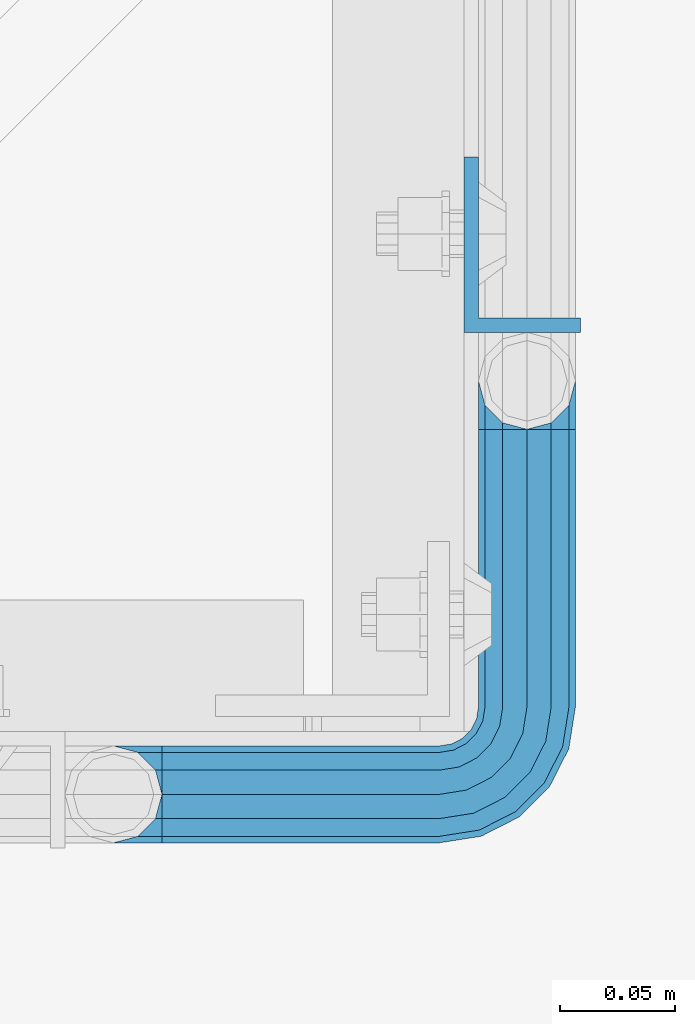
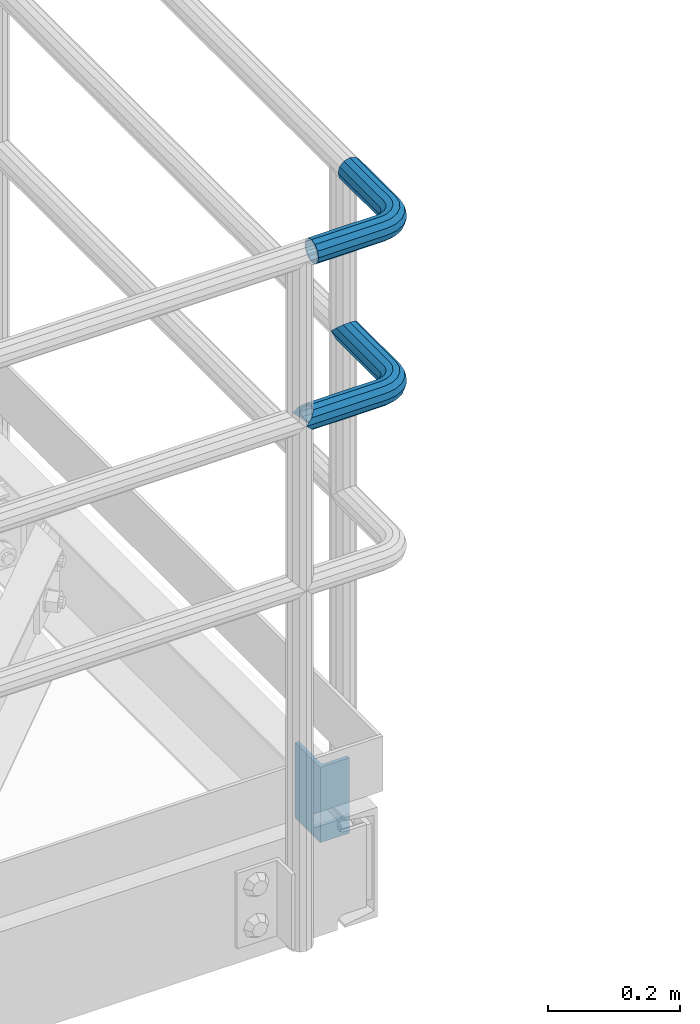
# One storey, part 1102 of 1876: 3 beams, 2 elements without a shape of their own.
"""IFC2X3 building model written with IfcOpenShell, lengths in millimetres."""

import ifcopenshell
import ifcopenshell.guid

model = None  # the IFC model being written
_history = None  # IfcOwnerHistory: only IFC2X3 demands one
_inside = {}  # id of a spatial element -> (the spatial element, [elements in it])
_under = {}  # id of a project, library or spatial element -> (it, [spatial elements below it])
_declared = {}  # id of a project -> (the project, [libraries it declares])
_typed = {}  # id of a type object -> (the type object, [elements of that type])
_made_of = {}  # id of a material, layer set ... -> (it, [elements and type objects made of it])


def new_model(schema):
    """Start an empty IFC model of exactly this schema.

    Asked for "IFC4X3", IfcOpenShell would pick the latest addendum, in which some entities
    have other attributes; the version numbers below select the first issue.
    IFC2X3 requires an IfcOwnerHistory on every rooted entity: one is made here for all.
    """
    global model, _history
    if schema == "IFC4X3":
        model = ifcopenshell.file(schema_version=(4, 3, 0, 0))
    else:
        model = ifcopenshell.file(schema=schema)
    _inside.clear()
    _under.clear()
    _declared.clear()
    _typed.clear()
    _made_of.clear()
    _history = None
    if model.schema == "IFC2X3":
        org = make("IfcOrganization", Name="unknown")
        user = make(
            "IfcPersonAndOrganization",
            ThePerson=make("IfcPerson", FamilyName="unknown"),
            TheOrganization=org,
        )
        app = make(
            "IfcApplication",
            ApplicationDeveloper=org,
            Version="unknown",
            ApplicationFullName="unknown",
            ApplicationIdentifier="unknown",
        )
        _history = make(
            "IfcOwnerHistory",
            OwningUser=user,
            OwningApplication=app,
            ChangeAction="ADDED",
            CreationDate=0,
        )
    return model


def make(cls, **values):
    """One entity of the class cls with the attributes given. An attribute that is None is left unset."""
    return model.create_entity(
        cls, **{name: value for name, value in values.items() if value is not None}
    )


def rooted(cls, **values):
    """An entity with a GlobalId (a new one), such as an element, a storey or a relation."""
    return make(cls, GlobalId=ifcopenshell.guid.new(), OwnerHistory=_history, **values)


def si_unit(unit_type, name, prefix=None):
    """IfcSIUnit, for example si_unit("LENGTHUNIT", "METRE", prefix="MILLI")."""
    return make("IfcSIUnit", UnitType=unit_type, Prefix=prefix, Name=name)


def assignment(units):
    """IfcUnitAssignment: the units of a project."""
    return None if units is None else make("IfcUnitAssignment", Units=units)


def point(xyz):
    """IfcCartesianPoint."""
    return None if xyz is None else make("IfcCartesianPoint", Coordinates=xyz)


def direction(xyz):
    """IfcDirection."""
    return None if xyz is None else make("IfcDirection", DirectionRatios=xyz)


def frame(location, z_axis=None, x_axis=None):
    """IfcAxis2Placement3D, a coordinate frame: its origin and axes. An axis left out is left unset."""
    return make(
        "IfcAxis2Placement3D",
        Location=point(location),
        Axis=direction(z_axis),
        RefDirection=direction(x_axis),
    )


def origin_with_axes():
    """The frame at (0, 0, 0) with the z axis (0, 0, 1) and the x axis (1, 0, 0) written out."""
    return frame((0.0, 0.0, 0.0), z_axis=(0.0, 0.0, 1.0), x_axis=(1.0, 0.0, 0.0))


def place(relative_to, where):
    """IfcLocalPlacement: puts the frame where relative to a parent placement (None: the world)."""
    return make(
        "IfcLocalPlacement", PlacementRelTo=relative_to, RelativePlacement=where
    )


def context(
    kind, dimensions, precision=None, world=None, true_north=None, identifier=None
):
    """IfcGeometricRepresentationContext, for example the 3D "Model" context."""
    return make(
        "IfcGeometricRepresentationContext",
        ContextIdentifier=identifier,
        ContextType=kind,
        CoordinateSpaceDimension=dimensions,
        Precision=precision,
        WorldCoordinateSystem=world,
        TrueNorth=true_north,
    )


def subcontext(parent, identifier, kind, view, scale=None):
    """IfcGeometricRepresentationSubContext, for example "Body" below "Model"."""
    return make(
        "IfcGeometricRepresentationSubContext",
        ContextIdentifier=identifier,
        ContextType=kind,
        ParentContext=parent,
        TargetScale=scale,
        TargetView=view,
    )


def project(units=None, contexts=None):
    """IfcProject with its units and contexts."""
    return rooted(
        "IfcProject",
        Name="project",
        RepresentationContexts=contexts,
        UnitsInContext=assignment(units),
    )


def spatial(cls, under=None, at=None, **own):
    """A site, building, storey or space (cls), placed at a placement, below another one or the project."""
    s = rooted(cls, ObjectPlacement=at, **own)
    if under is not None:
        _under.setdefault(under.id(), (under, []))[1].append(s)
    return s


def faces_of(points, faces, orient=None, outer=None):
    """IfcFace entities. A face is a list of loops; a loop is a list of indices into points, from 0.

    orient and outer hold one flag for each loop. By default every Orientation is true, the
    first loop of a face is its IfcFaceOuterBound and the others are IfcFaceBound.
    """
    made = []
    for i, loops in enumerate(faces):
        bounds = []
        for j, loop in enumerate(loops):
            is_outer = j == 0 if outer is None else outer[i][j]
            bounds.append(
                make(
                    "IfcFaceOuterBound" if is_outer else "IfcFaceBound",
                    Bound=make("IfcPolyLoop", Polygon=[points[k] for k in loop]),
                    Orientation=True if orient is None else orient[i][j],
                )
            )
        made.append(make("IfcFace", Bounds=bounds))
    return made


def faceted_brep(points, faces, orient=None, outer=None, voids=None):
    """IfcFacetedBrep: a solid bounded by flat faces; with voids (closed shells), ...WithVoids."""
    shared = [point(p) for p in points]
    hull = make("IfcClosedShell", CfsFaces=faces_of(shared, faces, orient, outer))
    if voids is None:
        return make("IfcFacetedBrep", Outer=hull)
    return make(
        "IfcFacetedBrepWithVoids",
        Outer=hull,
        Voids=[
            make(cls, CfsFaces=faces_of(shared, fs, o, b)) for cls, fs, o, b in voids
        ],
    )


def shape(context_of_items, identifier, shape_type, items):
    """IfcShapeRepresentation: the items that make up one representation, for example the "Body"."""
    return make(
        "IfcShapeRepresentation",
        ContextOfItems=context_of_items,
        RepresentationIdentifier=identifier,
        RepresentationType=shape_type,
        Items=items,
    )


def material(Name=None, Category=None):
    """IfcMaterial."""
    return make("IfcMaterial", Name=Name, Category=Category)


def made_of(thing, what):
    """Note that an element or type object is made of a material, layer set ...; save() writes the relation."""
    if what is not None:
        _made_of.setdefault(what.id(), (what, []))[1].append(thing)
    return thing


def type_object(cls, material=None, **own):
    """A type object (cls), such as IfcWallType, which elements share."""
    return made_of(rooted(cls, **own), material)


def element(
    cls,
    number,
    at=None,
    inside=None,
    cuts=None,
    type_object=None,
    material=None,
    context=None,
    identifier="Body",
    shape_type=None,
    held_by="IfcProductDefinitionShape",
    body=None,
    shapes=None,
    **own,
):
    """One element of the class cls, such as IfcWall. Its Tag is "e" and its number.

    at: its placement. inside: the storey or other place that contains it. cuts: it is an
    opening in that element (IfcRelVoidsElement). A single representation is given by context,
    identifier, shape_type and body (its items); several are given by shapes. held_by: the class
    of the entity that holds the representations. save() writes the other relations.
    """
    e = rooted(cls, Tag="e%d" % number, ObjectPlacement=at, **own)
    if body is not None:
        shapes = [shape(context, identifier, shape_type, body)]
    if shapes is not None:
        e.Representation = make(held_by, Representations=shapes)
    if inside is not None:
        _inside.setdefault(inside.id(), (inside, []))[1].append(e)
    if cuts is not None:
        rooted(
            "IfcRelVoidsElement", RelatingBuildingElement=cuts, RelatedOpeningElement=e
        )
    if type_object is not None:
        _typed.setdefault(type_object.id(), (type_object, []))[1].append(e)
    return made_of(e, material)


def aggregate(whole, parts):
    """IfcRelAggregates: a whole, such as a stair, and the parts it consists of."""
    return rooted("IfcRelAggregates", RelatingObject=whole, RelatedObjects=parts)


def save(model, path):
    """Write the relations noted so far, then the file.

    IfcRelAggregates (storeys below a building ...), IfcRelContainedInSpatialStructure (elements
    in a storey), IfcRelDefinesByType, IfcRelAssociatesMaterial and IfcRelDeclares: one each for
    every whole, place, type object, material and project.
    """
    for whole, parts in _under.values():
        aggregate(whole, parts)
    for where, things in _inside.values():
        rooted(
            "IfcRelContainedInSpatialStructure",
            RelatedElements=things,
            RelatingStructure=where,
        )
    for kind, things in _typed.values():
        rooted("IfcRelDefinesByType", RelatedObjects=things, RelatingType=kind)
    for what, things in _made_of.values():
        rooted("IfcRelAssociatesMaterial", RelatedObjects=things, RelatingMaterial=what)
    for by, libraries in _declared.values():
        rooted("IfcRelDeclares", RelatingContext=by, RelatedDefinitions=libraries)
    model.write(path)


model = new_model("IFC2X3")

# Units and contexts
model_context = context("Model", 3, precision=1e-05, world=origin_with_axes())
body_context = subcontext(model_context, "Body", "Model", "MODEL_VIEW")
ifc_project = project(units=[si_unit("LENGTHUNIT", "METRE", prefix="MILLI"), si_unit("AREAUNIT", "SQUARE_METRE"), si_unit("VOLUMEUNIT", "CUBIC_METRE"), si_unit("MASSUNIT", "GRAM", prefix="KILO"), si_unit("TIMEUNIT", "SECOND"), si_unit("PLANEANGLEUNIT", "RADIAN"), si_unit("SOLIDANGLEUNIT", "STERADIAN"), si_unit("THERMODYNAMICTEMPERATUREUNIT", "DEGREE_CELSIUS"), si_unit("LUMINOUSINTENSITYUNIT", "LUMEN")], contexts=[model_context])

# Site, building, storey
site_placement = place(None, origin_with_axes())
site = spatial("IfcSite", under=ifc_project, at=site_placement, CompositionType="ELEMENT")
building_placement = place(site_placement, origin_with_axes())
building = spatial("IfcBuilding", under=site, at=building_placement, Name="Undefined", CompositionType="ELEMENT")
storey_placement = place(building_placement, origin_with_axes())
storey = spatial("IfcBuildingStorey", under=building, at=storey_placement, Name="Undefined", CompositionType="ELEMENT", Elevation=0.0)

# Assembly, beams
assembly_1_placement = place(storey_placement, origin_with_axes())
assembly_1 = element("IfcElementAssembly", 1, at=assembly_1_placement, inside=storey, Name="HANDRAIL", AssemblyPlace="NOTDEFINED", PredefinedType="RIGID_FRAME")
ifc_material_1 = material()
beam_type_1 = type_object("IfcBeamType", Name="PIPE1-1/4STD", PredefinedType="NOTDEFINED")
beam_1_placement = place(assembly_1_placement, frame((6845.30143150122, -15432.4964042969, 8785.225), z_axis=(0.0, 0.0, -1.0), x_axis=(1.0, 0.0, 0.0)))
beam_1 = element("IfcBeam", 2, at=beam_1_placement, type_object=beam_type_1, material=ifc_material_1, Name="HANDRAIL", ObjectType="PIPE1-1/4STD", context=body_context, shape_type="Brep", body=[
    faceted_brep([(158.747132080079, -179.832000732422, 1.81898940354586e-12), (161.571584517495, -169.290999999999, -10.5409999999974), (161.571584517495, -169.290999999999, 10.5410000000029), (188.592132080079, -161.098037455637, -15.1779612267237), (179.829132080079, -158.749999999998, -17.525999999998), (179.829132080079, -158.749999999998, -21.0819999999985), (190.370132080079, -161.574452437415, -18.2575475625817), (190.370136997563, -161.574452437415, -13.3999563092402), (171.066132080079, -161.098040090908, -15.1779612267237), (169.288136997563, -161.574452437415, -13.3999661442085), (169.288132080079, -161.574452437415, -18.2575475625817), (164.651170853354, -166.211418581624, -8.76299999999719), (162.303132080079, -168.559457354899, 1.81898940354586e-12), (164.651170853354, -166.211418581624, 8.76300000000265), (169.288136997563, -161.574452437415, 13.3999661442122), (169.288132080079, -161.574452437415, 18.2575475625854), (171.066132080079, -161.098040090908, 15.1779612267292), (179.829132080079, -158.749999999998, 17.5260000000017), (179.829132080079, -158.749999999998, 21.0820000000022), (188.592132080079, -161.098037455637, 15.1779612267292), (190.370136997563, -161.574452437415, 13.3999563092439), (190.370132080079, -161.574452437415, 18.2575475625854), (200.911136997564, -179.831999999999, 1.81898940354586e-12), (198.086679642663, -169.290999999999, 10.5410000000029), (198.086679642663, -169.290999999999, -10.5409999999974), (195.007093306805, -166.211408746656, 8.76300000000265), (197.355132080079, -168.55944751993, 1.81898940354586e-12), (195.007093306805, -166.211408746656, -8.76299999999719), (141.729133605959, 21.0819999999967, 3.63797880709171e-12), (141.72913360596, 18.2575475625799, -10.5409999999956), (10.5409999957128, 18.2575475579433, -10.5409999999993), (9.09494701772928e-13, 21.0820000000003, 0.0), (10.5409999999983, 18.2575475625836, 10.5410000000011), (141.729133605959, 18.2575475625799, 10.5410000000047), (141.729133605959, 10.5409999999974, 18.2575475625872), (18.2575475625817, 10.5409999999993, 18.2575475625836), (141.729133605958, -3.63797880709171e-12, 21.082000000004), (21.0819999999985, 1.81898940354586e-12, 21.0820000000003), (141.729133605958, -21.0820000000022, 3.63797880709171e-12), (141.729133605959, -18.2575475625872, -10.5409999999956), (147.860788147674, -19.2287062354389, -10.5409999999956), (146.987984344709, -21.9149201310101, 3.63797880709171e-12), (141.729133605958, -18.2575475625872, 10.5410000000047), (147.860788147674, -19.2287062354389, 10.5410000000047), (141.729133605958, -10.5410000000029, 18.2575475625872), (150.245332482414, -11.8898333927427, 18.2575475625872), (153.50268062012, -1.86474665447531, 21.082000000004), (156.760028757826, 8.16034008379211, 18.257547562589), (159.144573092567, 15.4992129264883, 10.5410000000047), (160.017376895533, 18.1854268220595, 5.45696821063757e-12), (159.144573092567, 15.4992129264883, -10.5409999999956), (141.72913360596, 10.5409999999974, -18.2575475625799), (156.760028757827, 8.16034008379211, -18.2575475625781), (141.729133605959, -3.63797880709171e-12, -21.0819999999949), (153.502680620121, -1.86474665447531, -21.0819999999949), (141.729133605959, -10.5410000000029, -18.2575475625799), (150.245332482415, -11.8898333927427, -18.2575475625781), (190.370132080081, -38.0999984741229, -18.2575475625781), (198.086679642664, -38.0999984741247, -10.5409999999956), (179.829132080081, -38.0999984741229, -21.0819999999949), (169.288132080081, -38.0999984741247, -18.2575475625781), (161.571584517497, -38.0999984741247, -10.5409999999956), (158.747132080079, -38.0999984741247, 5.45696821063757e-12), (161.571584517496, -38.0999984741247, 10.5410000000047), (169.28813208008, -38.0999984741247, 18.257547562589), (179.82913208008, -38.0999984741247, 21.082000000004), (190.37013208008, -38.0999984741247, 18.257547562589), (198.086679642664, -38.0999984741247, 10.5410000000047), (200.91113208008, -38.0999984741247, 5.45696821063757e-12), (198.014558902142, -19.8117551845498, 5.45696821063757e-12), (195.328345006572, -20.6845589875156, -10.5409999999938), (195.328345006572, -20.6845589875156, 10.5410000000047), (187.989472163875, -23.0691033222574, 18.257547562589), (177.964385425607, -26.3264514599632, 21.0820000000058), (167.93929868734, -29.583799597669, 18.257547562589), (160.600425844644, -31.968343932409, 10.5410000000047), (157.914211949073, -32.8411477353748, 5.45696821063757e-12), (160.600425844644, -31.968343932409, -10.5409999999956), (167.939298687341, -29.583799597669, -18.2575475625781), (177.964385425608, -26.3264514599614, -21.0819999999949), (187.989472163876, -23.0691033222556, -18.2575475625781), (187.323346110924, -4.97386405835823, -10.5409999999938), (181.080527994891, -9.50953691425821, -18.2575475625781), (189.608376132597, -3.31369256984362, 5.45696821063757e-12), (187.323346110923, -4.97386405835823, 10.5410000000047), (181.08052799489, -9.50953691425821, 18.257547562589), (172.552679857184, -15.7053812586728, 21.0820000000058), (164.024831719476, -21.9012256030874, 18.257547562589), (157.782013603444, -26.4368984589855, 10.5410000000047), (155.49698358177, -28.0970699475001, 5.45696821063757e-12), (157.782013603444, -26.4368984589855, -10.5409999999956), (164.024831719477, -21.9012256030855, -18.2575475625781), (172.552679857185, -15.705381258671, -21.0819999999949), (170.319595165825, 1.25139591480729, -18.2575475625781), (164.123750821412, -7.27645222289902, -21.0819999999949), (174.855268021725, 7.49421403083943, -10.5409999999956), (176.51543951024, 9.7792440525136, 5.45696821063757e-12), (174.855268021724, 7.49421403083943, 10.5410000000047), (170.319595165825, 1.25139591480729, 18.257547562589), (164.123750821411, -7.27645222289902, 21.0820000000058), (157.927906476996, -15.8043003606053, 18.257547562589), (153.392233621096, -22.0471184766393, 10.5410000000047), (151.732062132583, -24.3321484983135, 3.63797880709171e-12), (153.392233621097, -22.0471184766393, -10.5409999999956), (157.927906476997, -15.8043003606053, -18.2575475625781), (10.5409999957128, -18.2575475672238, -10.5409999999993), (18.2575475625817, -10.5410000000011, -18.2575475625836), (21.0819999999985, 0.0, -21.0819999999985), (18.2575475625817, 10.5409999999993, -18.2575475625836), (141.72913360596, 8.76299999999719, -15.1779612267219), (141.72913360596, 15.1779612267237, -8.76299999999537), (13.6205863358573, 15.1779612267255, -8.76299999999901), (18.2575475625817, 10.5410000000011, -13.3999612267235), (18.7339612267251, 8.76299999999901, -15.1779612267255), (141.729133605959, 17.525999999998, 3.63797880709171e-12), (11.2725475625839, 17.5259999999998, 0.0), (13.6205863358573, 15.1779612267255, 8.76300000000083), (18.2575475625817, 10.5410000000011, 13.3999612267253), (141.729133605959, 15.1779612267237, 8.76300000000447), (141.729133605959, 8.76299999999719, 15.177961226731), (18.7339612267251, 8.76299999999901, 15.1779612267273), (21.0819999999985, 1.81898940354586e-12, 17.5259999999998), (141.729133605958, -3.63797880709171e-12, 17.5260000000035), (141.729133605958, -8.76300000000265, 15.177961226731), (18.7339612267233, -8.76300000000083, 15.1779612267273), (141.729133605958, -15.1779612267292, 8.76300000000447), (141.729133605958, -17.5260000000035, 3.63797880709171e-12), (11.2725475625793, -17.5259999999998, 0.0), (13.6205863358537, -15.1779612267255, 8.76300000000083), (18.2575475625817, -10.5409999999974, 13.3999612267289), (18.2575475625817, -10.5410000000011, 18.2575475625836), (10.5409999999983, -18.2575475625836, 10.5410000000011), (9.09494701772928e-13, -21.0820000000003, 0.0), (13.6205863358537, -15.1779612267255, -8.76299999999901), (18.2575475625817, -10.5409999999974, -13.3999612267271), (141.729133605959, -15.1779612267292, -8.76299999999537), (141.729133605959, -8.76300000000265, -15.1779612267219), (141.729133605959, -3.63797880709171e-12, -17.5259999999962), (21.0819999999985, 0.0, -17.5259999999998), (18.7339612267233, -8.76300000000083, -15.1779612267255), (153.502680620121, -1.86474665447531, -17.5259999999962), (156.210596541829, 6.46936159781944, -15.1779612267219), (158.192928579143, 12.570352274277, -8.76299999999537), (158.918512463535, 14.8034698501142, 5.45696821063757e-12), (158.192928579142, 12.570352274277, 8.76300000000447), (156.210596541828, 6.46936159781944, 15.177961226731), (153.50268062012, -1.86474665447531, 17.5260000000053), (150.794764698413, -10.1988549067701, 15.177961226731), (148.812432661099, -16.2998455832294, 8.76300000000447), (148.086848776706, -18.5329631590648, 3.63797880709171e-12), (148.812432661099, -16.2998455832294, -8.76299999999537), (150.794764698413, -10.1988549067701, -15.1779612267219), (158.972988655572, -14.3658681446068, -15.1779612267219), (164.123750821412, -7.27645222289902, -17.5259999999944), (155.202369052476, -19.5556807952853, -8.76299999999537), (153.822226489734, -21.4552840663146, 5.45696821063757e-12), (155.202369052475, -19.5556807952853, 8.76300000000447), (158.972988655572, -14.3658681446068, 15.177961226731), (164.123750821411, -7.27645222289902, 17.5260000000053), (169.274512987249, -0.187036301191256, 15.177961226731), (173.045132590347, 5.00277634948725, 8.76300000000447), (174.425275153088, 6.90237962051651, 5.45696821063757e-12), (173.045132590347, 5.00277634948725, -8.76299999999537), (169.27451298725, -0.187036301191256, -15.1779612267219), (172.552679857184, -15.705381258671, -17.5259999999944), (179.642095778892, -10.5546190928326, -15.1779612267201), (165.463263935476, -20.8561434245112, -15.1779612267219), (160.273451284798, -24.626763027607, -8.76299999999537), (158.373848013768, -26.0069055903496, 5.45696821063757e-12), (160.273451284797, -24.6267630276088, 8.76300000000447), (165.463263935476, -20.8561434245112, 15.177961226731), (172.552679857184, -15.7053812586728, 17.5260000000053), (179.642095778891, -10.5546190928344, 15.177961226731), (184.83190842957, -6.78399948973674, 8.76300000000447), (186.7315117006, -5.40385692699419, 5.45696821063757e-12), (184.83190842957, -6.78399948973674, -8.76299999999537), (186.298493677902, -23.6185355382549, -15.1779612267201), (192.399484354361, -21.6362035009406, -8.76299999999537), (177.964385425608, -26.3264514599614, -17.5259999999944), (169.630277173314, -29.0343673816697, -15.1779612267219), (163.529286496855, -31.016699418984, -8.76299999999537), (161.296168921019, -31.7422833033779, 5.45696821063757e-12), (163.529286496854, -31.016699418984, 8.76300000000447), (169.630277173313, -29.0343673816697, 15.177961226731), (177.964385425607, -26.3264514599632, 17.5260000000053), (186.298493677902, -23.6185355382549, 15.177961226731), (192.399484354361, -21.6362035009406, 8.76300000000447), (194.632601930197, -20.9106196165467, 5.45696821063757e-12), (195.007093306806, -38.0999984741247, -8.76299999999537), (197.355132080081, -38.0999984741247, 5.45696821063757e-12), (188.592132080081, -38.0999984741229, -15.1779612267219), (179.829132080081, -38.0999984741229, -17.5259999999944), (171.066132080081, -38.0999984741247, -15.1779612267219), (164.651170853354, -38.0999984741247, -8.76299999999537), (162.303132080079, -38.0999984741247, 5.45696821063757e-12), (164.651170853354, -38.0999984741247, 8.76300000000447), (171.06613208008, -38.0999984741247, 15.177961226731), (179.82913208008, -38.0999984741247, 17.5260000000053), (188.59213208008, -38.0999984741247, 15.177961226731), (195.007093306806, -38.0999984741247, 8.76300000000447)], [[[0, 1, 2]], [[3, 4, 5, 6, 7]], [[8, 9, 10, 5, 4]], [[2, 1, 10, 9, 11, 12, 13, 14, 15]], [[15, 14, 16, 17, 18]], [[18, 17, 19, 20, 21]], [[22, 23, 24]], [[21, 20, 25, 26, 27, 7, 6, 24, 23]], [[28, 29, 30, 31]], [[31, 30, 32]], [[33, 28, 31, 32]], [[34, 33, 32, 35]], [[36, 34, 35, 37]], [[38, 39, 40, 41]], [[42, 38, 41, 43]], [[44, 42, 43, 45]], [[36, 44, 45, 46]], [[34, 36, 46, 47]], [[33, 34, 47, 48]], [[28, 33, 48, 49]], [[29, 28, 49, 50]], [[51, 29, 50, 52]], [[53, 51, 52, 54]], [[55, 53, 54, 56]], [[57, 58, 24, 6]], [[59, 57, 6, 5]], [[60, 59, 5, 10]], [[61, 60, 10, 1]], [[62, 61, 1, 0]], [[63, 62, 0, 2]], [[64, 63, 2, 15]], [[65, 64, 15, 18]], [[66, 65, 18, 21]], [[67, 66, 21, 23]], [[68, 67, 23, 22]], [[58, 68, 22, 24]], [[69, 68, 58, 70]], [[71, 67, 68, 69]], [[72, 66, 67, 71]], [[73, 65, 66, 72]], [[74, 64, 65, 73]], [[75, 63, 64, 74]], [[76, 62, 63, 75]], [[77, 61, 62, 76]], [[78, 60, 61, 77]], [[79, 59, 60, 78]], [[80, 57, 59, 79]], [[70, 58, 57, 80]], [[81, 70, 80, 82]], [[83, 69, 70, 81]], [[84, 71, 69, 83]], [[85, 72, 71, 84]], [[86, 73, 72, 85]], [[87, 74, 73, 86]], [[88, 75, 74, 87]], [[89, 76, 75, 88]], [[90, 77, 76, 89]], [[91, 78, 77, 90]], [[92, 79, 78, 91]], [[82, 80, 79, 92]], [[93, 82, 92, 94]], [[95, 81, 82, 93]], [[96, 83, 81, 95]], [[97, 84, 83, 96]], [[98, 85, 84, 97]], [[99, 86, 85, 98]], [[100, 87, 86, 99]], [[101, 88, 87, 100]], [[102, 89, 88, 101]], [[103, 90, 89, 102]], [[104, 91, 90, 103]], [[94, 92, 91, 104]], [[54, 94, 104, 56]], [[52, 93, 94, 54]], [[50, 95, 93, 52]], [[49, 96, 95, 50]], [[48, 97, 96, 49]], [[47, 98, 97, 48]], [[46, 99, 98, 47]], [[45, 100, 99, 46]], [[43, 101, 100, 45]], [[41, 102, 101, 43]], [[40, 103, 102, 41]], [[56, 104, 103, 40]], [[39, 55, 56, 40]], [[55, 39, 105, 106]], [[53, 55, 106, 107]], [[51, 53, 107, 108]], [[29, 51, 108, 30]], [[109, 110, 111, 112, 113]], [[110, 114, 115, 111]], [[32, 30, 108, 112, 111, 115, 116, 117, 35]], [[114, 118, 116, 115]], [[116, 118, 119, 120, 117]], [[35, 117, 120, 121, 37]], [[119, 122, 121, 120]], [[122, 123, 124, 121]], [[125, 126, 127, 128]], [[123, 125, 128, 129, 124]], [[37, 121, 124, 129, 130]], [[44, 36, 37, 130]], [[42, 44, 130, 131]], [[38, 42, 131, 132]], [[39, 38, 132, 105]], [[131, 105, 132]], [[130, 129, 128, 127, 133, 134, 106, 105, 131]], [[126, 135, 133, 127]], [[136, 137, 138, 139]], [[133, 135, 136, 139, 134]], [[138, 107, 106, 134, 139]], [[113, 112, 108, 107, 138]], [[137, 109, 113, 138]], [[109, 137, 140, 141]], [[110, 109, 141, 142]], [[114, 110, 142, 143]], [[118, 114, 143, 144]], [[119, 118, 144, 145]], [[122, 119, 145, 146]], [[123, 122, 146, 147]], [[125, 123, 147, 148]], [[126, 125, 148, 149]], [[135, 126, 149, 150]], [[136, 135, 150, 151]], [[137, 136, 151, 140]], [[151, 152, 153, 140]], [[150, 154, 152, 151]], [[149, 155, 154, 150]], [[148, 156, 155, 149]], [[147, 157, 156, 148]], [[146, 158, 157, 147]], [[145, 159, 158, 146]], [[144, 160, 159, 145]], [[143, 161, 160, 144]], [[142, 162, 161, 143]], [[141, 163, 162, 142]], [[140, 153, 163, 141]], [[153, 164, 165, 163]], [[152, 166, 164, 153]], [[154, 167, 166, 152]], [[155, 168, 167, 154]], [[156, 169, 168, 155]], [[157, 170, 169, 156]], [[158, 171, 170, 157]], [[159, 172, 171, 158]], [[160, 173, 172, 159]], [[161, 174, 173, 160]], [[162, 175, 174, 161]], [[163, 165, 175, 162]], [[165, 176, 177, 175]], [[164, 178, 176, 165]], [[166, 179, 178, 164]], [[167, 180, 179, 166]], [[168, 181, 180, 167]], [[169, 182, 181, 168]], [[170, 183, 182, 169]], [[171, 184, 183, 170]], [[172, 185, 184, 171]], [[173, 186, 185, 172]], [[174, 187, 186, 173]], [[175, 177, 187, 174]], [[177, 188, 189, 187]], [[176, 190, 188, 177]], [[178, 191, 190, 176]], [[179, 192, 191, 178]], [[180, 193, 192, 179]], [[181, 194, 193, 180]], [[182, 195, 194, 181]], [[183, 196, 195, 182]], [[184, 197, 196, 183]], [[185, 198, 197, 184]], [[186, 199, 198, 185]], [[187, 189, 199, 186]], [[199, 189, 26, 25]], [[19, 198, 199, 25, 20]], [[197, 198, 19, 17]], [[196, 197, 17, 16]], [[13, 195, 196, 16, 14]], [[194, 195, 13, 12]], [[193, 194, 12, 11]], [[192, 193, 11, 9, 8]], [[191, 192, 8, 4]], [[190, 191, 4, 3]], [[188, 190, 3, 7, 27]], [[189, 188, 27, 26]]]),
])
beam_2_placement = place(assembly_1_placement, frame((6866.38386300243, -15432.4964042969, 9090.025), z_axis=(0.0, 0.0, -1.0), x_axis=(1.0, 0.0, 0.0)))
beam_2 = element("IfcBeam", 3, at=beam_2_placement, type_object=beam_type_1, material=ifc_material_1, Name="HANDRAIL", ObjectType="PIPE1-1/4STD", context=body_context, shape_type="Brep", body=[
    faceted_brep([(9.09494701772928e-13, -21.0820000000003, 0.0), (0.0, -18.2575475625836, -10.5409999999993), (120.646705627442, -18.2575475625854, -10.5409999999956), (120.646705627441, -21.0820000000022, 3.63797880709171e-12), (0.0, -10.5410000000002, -18.2575475625836), (120.646705627442, -10.5410000000029, -18.2575475625799), (-4.28826751885936e-09, 0.0, -21.0820000000003), (120.646705627443, -3.63797880709171e-12, -21.0819999999967), (0.0, 10.5410000000002, -18.2575475625836), (120.646705627443, 10.5409999999974, -18.2575475625799), (0.0, 18.2575475625836, -10.5409999999993), (120.646705627443, 18.2575475625799, -10.5409999999956), (9.09494701772928e-13, 21.0820000000003, 0.0), (120.646705627443, 21.0819999999967, 3.63797880709171e-12), (0.0, 18.2575475625836, 10.5409999999993), (120.646705627442, 18.2575475625799, 10.5410000000047), (0.0, 10.5410000000002, 18.2575475625836), (120.646705627442, 10.5409999999974, 18.2575475625872), (0.0, 0.0, 21.0820000000003), (120.646705627441, -3.63797880709171e-12, 21.082000000004), (0.0, -10.5410000000002, 18.2575475625836), (120.646705627441, -10.5410000000029, 18.2575475625872), (0.0, -18.2575475625836, 10.5409999999993), (120.646705627441, -18.2575475625872, 10.5410000000047), (0.0, -17.5259999999998, 0.0), (0.0, -15.1779612267264, 8.76300000000083), (120.646705627441, -15.1779612267292, 8.76300000000447), (120.646705627441, -17.5260000000035, 3.63797880709171e-12), (0.0, -8.76299999999992, 15.1779612267255), (120.646705627441, -8.76300000000265, 15.177961226731), (0.0, 0.0, 17.5259999999998), (120.646705627441, -3.63797880709171e-12, 17.5260000000035), (0.0, 8.76299999999992, 15.1779612267255), (120.646705627442, 8.76299999999719, 15.177961226731), (0.0, 15.1779612267264, 8.76300000000083), (120.646705627442, 15.1779612267237, 8.76300000000447), (0.0, 17.5259999999998, 0.0), (120.646705627443, 17.525999999998, 3.63797880709171e-12), (0.0, 15.1779612267264, -8.76300000000083), (120.646705627443, 15.1779612267237, -8.76299999999537), (0.0, 8.76299999999992, -15.1779612267255), (120.646705627443, 8.76299999999719, -15.1779612267219), (0.0, 0.0, -17.5259999999998), (120.646705627443, -3.63797880709171e-12, -17.5259999999962), (0.0, -8.76299999999992, -15.1779612267255), (120.646705627442, -8.76300000000265, -15.1779612267219), (0.0, -15.1779612267264, -8.76300000000083), (120.646705627442, -15.1779612267292, -8.76299999999537), (125.905556366192, -21.9149201310101, 3.63797880709171e-12), (126.778360169157, -19.2287062354389, 10.5410000000047), (129.162904503898, -11.8898333927427, 18.2575475625872), (132.420252641604, -1.86474665447531, 21.082000000004), (135.677600779311, 8.16034008379211, 18.257547562589), (138.062145114052, 15.4992129264883, 10.5410000000047), (138.934948917018, 18.1854268220577, 5.45696821063757e-12), (138.062145114057, 15.4992129264865, -10.5409999999956), (135.677600779312, 8.16034008379211, -18.2575475625781), (132.420252641606, -1.86474665447531, -21.0819999999949), (129.162904503899, -11.8898333927427, -18.2575475625799), (126.778360169158, -19.2287062354389, -10.5409999999956), (137.83608448502, 14.8034698501124, 5.45696821063757e-12), (137.110500600631, 12.5703522742751, 8.76300000000447), (135.128168563312, 6.46936159781944, 15.177961226731), (132.420252641605, -1.86474665447531, 17.5260000000053), (129.712336719896, -10.1988549067701, 15.177961226731), (127.730004682582, -16.2998455832294, 8.76300000000447), (127.004420798189, -18.5329631590648, 3.63797880709171e-12), (127.730004682582, -16.2998455832294, -8.76299999999537), (129.712336719897, -10.1988549067701, -15.1779612267219), (132.420252641606, -1.86474665447531, -17.5259999999962), (135.128168563313, 6.46936159781762, -15.1779612267219), (137.110500600627, 12.570352274277, -8.76299999999537), (149.237167187315, 1.25139591480183, 18.257547562589), (153.772840043216, 7.49421403083397, 10.5410000000047), (143.041322842899, -7.27645222290448, 21.082000000004), (136.845478498483, -15.804300360609, 18.257547562589), (132.309805642582, -22.0471184766411, 10.5410000000047), (130.649634154068, -24.3321484983135, 3.63797880709171e-12), (132.309805642582, -22.0471184766411, -10.5409999999956), (136.845478498484, -15.804300360609, -18.2575475625781), (143.0413228429, -7.27645222290266, -21.0819999999949), (149.237167187316, 1.25139591480183, -18.2575475625781), (153.772840043217, 7.49421403083397, -10.5409999999956), (155.433011531732, 9.77924405250815, 5.45696821063757e-12), (151.962704611838, 5.00277634947997, -8.76299999999537), (153.342847174579, 6.90237962051106, 5.45696821063757e-12), (148.19208500874, -0.187036301196713, -15.1779612267219), (143.0413228429, -7.27645222290266, -17.5259999999944), (137.89056067706, -14.3658681446104, -15.1779612267219), (134.119941073962, -19.5556807952871, -8.76299999999537), (132.73979851122, -21.4552840663182, 3.63797880709171e-12), (134.119941073961, -19.5556807952871, 8.76300000000447), (137.89056067706, -14.3658681446104, 15.177961226731), (143.041322842899, -7.27645222290448, 17.5260000000053), (148.192085008739, -0.187036301196713, 15.177961226731), (151.962704611838, 5.00277634947997, 8.76300000000447), (159.998100016372, -9.50953691425639, 18.257547562589), (166.240918132405, -4.97386405835641, 10.5410000000047), (151.470251878665, -15.705381258671, 21.082000000004), (142.942403740959, -21.9012256030855, 18.257547562589), (136.699585624926, -26.4368984589855, 10.5410000000047), (134.414555603253, -28.0970699475001, 3.63797880709171e-12), (136.699585624927, -26.4368984589855, -10.5409999999956), (142.942403740959, -21.9012256030855, -18.2575475625781), (151.470251878666, -15.705381258671, -21.0819999999949), (159.998100016373, -9.50953691425639, -18.2575475625781), (166.240918132402, -4.97386405835277, -10.5409999999956), (168.525948154078, -3.31369256984181, 5.45696821063757e-12), (163.749480451052, -6.78399948973492, -8.76299999999537), (165.649083722081, -5.40385692699419, 5.45696821063757e-12), (158.559667800373, -10.5546190928326, -15.1779612267219), (151.470251878665, -15.705381258671, -17.5259999999944), (144.380835956958, -20.8561434245094, -15.1779612267219), (139.19102330628, -24.626763027607, -8.76299999999537), (137.29142003525, -26.0069055903477, 3.63797880709171e-12), (139.19102330628, -24.626763027607, 8.76300000000447), (144.380835956958, -20.8561434245094, 15.177961226731), (151.470251878665, -15.705381258671, 17.5260000000053), (158.559667800373, -10.5546190928326, 15.177961226731), (163.749480451049, -6.78399948973129, 8.76300000000447), (166.907044185355, -23.069103322252, 18.257547562589), (174.245917028052, -20.6845589875102, 10.5410000000047), (156.881957447088, -26.3264514599596, 21.082000000004), (146.856870708822, -29.5837995976653, 18.2575475625872), (139.517997866125, -31.9683439324072, 10.5410000000047), (136.831783970555, -32.8411477353729, 3.63797880709171e-12), (139.517997866125, -31.9683439324072, -10.5409999999956), (146.856870708822, -29.5837995976653, -18.2575475625781), (156.881957447089, -26.3264514599578, -21.0819999999949), (166.907044185356, -23.0691033222502, -18.2575475625781), (174.245917028052, -20.6845589875102, -10.5409999999956), (176.932130923622, -19.8117551845444, 5.45696821063757e-12), (171.317056375841, -21.6362035009352, -8.76299999999537), (173.550173951677, -20.9106196165412, 5.45696821063757e-12), (165.216065699383, -23.6185355382495, -15.1779612267219), (156.881957447089, -26.3264514599578, -17.5259999999944), (148.547849194794, -29.034367381666, -15.1779612267219), (142.446858518336, -31.0166994189822, -8.76299999999537), (140.2137409425, -31.7422833033743, 3.63797880709171e-12), (142.446858518336, -31.0166994189822, 8.76300000000447), (148.547849194794, -29.034367381666, 15.177961226731), (156.881957447088, -26.3264514599596, 17.5260000000053), (165.216065699382, -23.6185355382495, 15.177961226731), (171.317056375841, -21.6362035009352, 8.76300000000447), (148.205704101562, -38.0999984741229, -18.2575475625799), (140.489156538979, -38.0999984741229, -10.5409999999956), (158.746704101562, -38.0999984741229, -21.0819999999949), (169.287704101563, -38.0999984741229, -18.2575475625781), (177.004251664146, -38.0999984741229, -10.5409999999956), (179.828704101562, -38.0999984741247, 5.45696821063757e-12), (177.004251664145, -38.0999984741247, 10.5410000000047), (169.287704101562, -38.0999984741247, 18.257547562589), (158.746704101562, -38.0999984741247, 21.082000000004), (148.205704101561, -38.0999984741247, 18.2575475625872), (140.489156538979, -38.0999984741247, 10.5410000000047), (137.664704101562, -38.0999984741247, 5.45696821063757e-12), (173.924665328288, -38.0999984741247, -8.76299999999537), (176.272704101562, -38.0999984741247, 5.45696821063757e-12), (167.509704101562, -38.0999984741229, -15.1779612267219), (158.746704101562, -38.0999984741229, -17.5259999999962), (149.983704101563, -38.0999984741229, -15.1779612267219), (143.568742874836, -38.0999984741229, -8.76299999999537), (141.220704101563, -38.0999984741247, 5.45696821063757e-12), (143.568742874836, -38.0999984741247, 8.76300000000447), (149.983704101562, -38.0999984741247, 15.177961226731), (158.746704101562, -38.0999984741247, 17.5260000000053), (167.509704101562, -38.0999984741247, 15.177961226731), (173.924665328288, -38.0999984741247, 8.76300000000447), (140.489156538979, -158.75, -10.5409999999974), (137.664704101562, -158.75, 1.81898940354586e-12), (148.205704101562, -158.75, -18.2575475625817), (158.746704101562, -158.75, -21.0819999999985), (169.287704101563, -158.75, -18.2575475625817), (177.004251664146, -158.75, -10.5409999999974), (179.828704101563, -158.75, 1.81898940354586e-12), (177.004251664146, -158.75, 10.5410000000011), (169.287704101563, -158.75, 18.2575475625854), (158.746704101562, -158.75, 21.0820000000022), (148.205704101562, -158.75, 18.2575475625854), (140.489156538979, -158.75, 10.5410000000011), (143.568742874836, -158.75, 8.76300000000265), (141.220704101563, -158.75, 1.81898940354586e-12), (149.983704101563, -158.75, 15.1779612267273), (158.746704101562, -158.75, 17.5260000000017), (167.509704101562, -158.75, 15.1779612267273), (173.924665328289, -158.75, 8.76300000000265), (176.272704101562, -158.75, 1.81898940354586e-12), (173.924665328289, -158.75, -8.76299999999901), (167.509704101562, -158.75, -15.1779612267237), (158.746704101562, -158.75, -17.525999999998), (149.983704101563, -158.75, -15.1779612267237), (143.568742874836, -158.75, -8.76299999999901)], [[[0, 1, 2, 3]], [[1, 4, 5, 2]], [[4, 6, 7, 5]], [[6, 8, 9, 7]], [[8, 10, 11, 9]], [[10, 12, 13, 11]], [[12, 14, 15, 13]], [[14, 16, 17, 15]], [[16, 18, 19, 17]], [[18, 20, 21, 19]], [[20, 22, 23, 21]], [[22, 0, 3, 23]], [[24, 25, 26, 27]], [[25, 28, 29, 26]], [[28, 30, 31, 29]], [[30, 32, 33, 31]], [[32, 34, 35, 33]], [[34, 36, 37, 35]], [[36, 38, 39, 37]], [[38, 40, 41, 39]], [[40, 42, 43, 41]], [[42, 44, 45, 43]], [[44, 46, 47, 45]], [[46, 24, 27, 47]], [[22, 20, 18, 16, 14, 12, 10, 8, 6, 4, 1, 0], [46, 44, 42, 40, 38, 36, 34, 32, 30, 28, 25, 24]], [[23, 3, 48, 49]], [[21, 23, 49, 50]], [[19, 21, 50, 51]], [[17, 19, 51, 52]], [[15, 17, 52, 53]], [[13, 15, 53, 54]], [[11, 13, 54, 55]], [[9, 11, 55, 56]], [[7, 9, 56, 57]], [[5, 7, 57, 58]], [[2, 5, 58, 59]], [[3, 2, 59, 48]], [[35, 37, 60, 61]], [[33, 35, 61, 62]], [[31, 33, 62, 63]], [[29, 31, 63, 64]], [[26, 29, 64, 65]], [[27, 26, 65, 66]], [[47, 27, 66, 67]], [[45, 47, 67, 68]], [[43, 45, 68, 69]], [[41, 43, 69, 70]], [[39, 41, 70, 71]], [[37, 39, 71, 60]], [[52, 72, 73, 53]], [[51, 74, 72, 52]], [[50, 75, 74, 51]], [[49, 76, 75, 50]], [[48, 77, 76, 49]], [[59, 78, 77, 48]], [[58, 79, 78, 59]], [[57, 80, 79, 58]], [[56, 81, 80, 57]], [[55, 82, 81, 56]], [[54, 83, 82, 55]], [[53, 73, 83, 54]], [[71, 84, 85, 60]], [[70, 86, 84, 71]], [[69, 87, 86, 70]], [[68, 88, 87, 69]], [[67, 89, 88, 68]], [[66, 90, 89, 67]], [[65, 91, 90, 66]], [[64, 92, 91, 65]], [[63, 93, 92, 64]], [[62, 94, 93, 63]], [[61, 95, 94, 62]], [[60, 85, 95, 61]], [[72, 96, 97, 73]], [[74, 98, 96, 72]], [[75, 99, 98, 74]], [[76, 100, 99, 75]], [[77, 101, 100, 76]], [[78, 102, 101, 77]], [[79, 103, 102, 78]], [[80, 104, 103, 79]], [[81, 105, 104, 80]], [[82, 106, 105, 81]], [[83, 107, 106, 82]], [[73, 97, 107, 83]], [[84, 108, 109, 85]], [[86, 110, 108, 84]], [[87, 111, 110, 86]], [[88, 112, 111, 87]], [[89, 113, 112, 88]], [[90, 114, 113, 89]], [[91, 115, 114, 90]], [[92, 116, 115, 91]], [[93, 117, 116, 92]], [[94, 118, 117, 93]], [[95, 119, 118, 94]], [[85, 109, 119, 95]], [[96, 120, 121, 97]], [[98, 122, 120, 96]], [[99, 123, 122, 98]], [[100, 124, 123, 99]], [[101, 125, 124, 100]], [[102, 126, 125, 101]], [[103, 127, 126, 102]], [[104, 128, 127, 103]], [[105, 129, 128, 104]], [[106, 130, 129, 105]], [[107, 131, 130, 106]], [[97, 121, 131, 107]], [[108, 132, 133, 109]], [[110, 134, 132, 108]], [[111, 135, 134, 110]], [[112, 136, 135, 111]], [[113, 137, 136, 112]], [[114, 138, 137, 113]], [[115, 139, 138, 114]], [[116, 140, 139, 115]], [[117, 141, 140, 116]], [[118, 142, 141, 117]], [[119, 143, 142, 118]], [[109, 133, 143, 119]], [[127, 144, 145, 126]], [[128, 146, 144, 127]], [[129, 147, 146, 128]], [[130, 148, 147, 129]], [[131, 149, 148, 130]], [[121, 150, 149, 131]], [[120, 151, 150, 121]], [[122, 152, 151, 120]], [[123, 153, 152, 122]], [[124, 154, 153, 123]], [[125, 155, 154, 124]], [[126, 145, 155, 125]], [[132, 156, 157, 133]], [[134, 158, 156, 132]], [[135, 159, 158, 134]], [[136, 160, 159, 135]], [[137, 161, 160, 136]], [[138, 162, 161, 137]], [[139, 163, 162, 138]], [[140, 164, 163, 139]], [[141, 165, 164, 140]], [[142, 166, 165, 141]], [[143, 167, 166, 142]], [[133, 157, 167, 143]], [[155, 145, 168, 169]], [[145, 144, 170, 168]], [[144, 146, 171, 170]], [[146, 147, 172, 171]], [[147, 148, 173, 172]], [[148, 149, 174, 173]], [[149, 150, 175, 174]], [[150, 151, 176, 175]], [[151, 152, 177, 176]], [[152, 153, 178, 177]], [[153, 154, 179, 178]], [[154, 155, 169, 179]], [[162, 163, 180, 181]], [[163, 164, 182, 180]], [[164, 165, 183, 182]], [[165, 166, 184, 183]], [[166, 167, 185, 184]], [[167, 157, 186, 185]], [[157, 156, 187, 186]], [[156, 158, 188, 187]], [[158, 159, 189, 188]], [[159, 160, 190, 189]], [[160, 161, 191, 190]], [[161, 162, 181, 191]], [[170, 171, 172, 173, 174, 175, 176, 177, 178, 179, 169, 168], [182, 183, 184, 185, 186, 187, 188, 189, 190, 191, 181, 180]]]),
])
aggregate(assembly_1, [beam_1, beam_2])

# Assembly, beam
assembly_2_placement = place(storey_placement, origin_with_axes())
assembly_2 = element("IfcElementAssembly", 4, at=assembly_2_placement, inside=storey, Name="HANDRAIL", AssemblyPlace="NOTDEFINED", PredefinedType="RIGID_FRAME")
ifc_material_2 = material(Name="STEEL/A36")
beam_type_2 = type_object("IfcBeamType", Name="L3X2X1/4", PredefinedType="NOTDEFINED")
beam_3_placement = place(assembly_2_placement, frame((7023.09856849878, -15193.4824042969, 7966.075), z_axis=(0.0, 1.0, 0.0), x_axis=(0.0, 0.0, -1.0)))
beam_3 = element("IfcBeam", 5, at=beam_3_placement, type_object=beam_type_2, material=ifc_material_2, Name="ANGLE", ObjectType="L3X2X1/4", context=body_context, shape_type="Brep", body=[
    faceted_brep([(0.0, 25.3999999999996, -38.1000000000004), (0.0, 25.3999999999996, 38.1000000000004), (139.7, 25.3999999999996, 38.1000000000004), (139.7, 25.3999999999996, -38.1000000000004), (0.0, 19.0500000000002, 38.1000000000004), (139.7, 19.0500000000002, 38.1000000000004), (0.0, 19.0500000000002, -31.75), (139.7, 19.0500000000002, -31.75), (0.0, -25.3999999999996, -31.75), (139.7, -25.3999999999996, -31.75), (0.0, -25.3999999999996, -38.1000000000004), (139.7, -25.3999999999996, -38.1000000000004)], [[[0, 1, 2, 3]], [[1, 4, 5, 2]], [[4, 6, 7, 5]], [[6, 8, 9, 7]], [[8, 10, 11, 9]], [[10, 0, 3, 11]], [[5, 7, 9, 11, 3, 2]], [[10, 8, 6, 4, 1, 0]]]),
])
aggregate(assembly_2, [beam_3])

save(model, "model.ifc")
